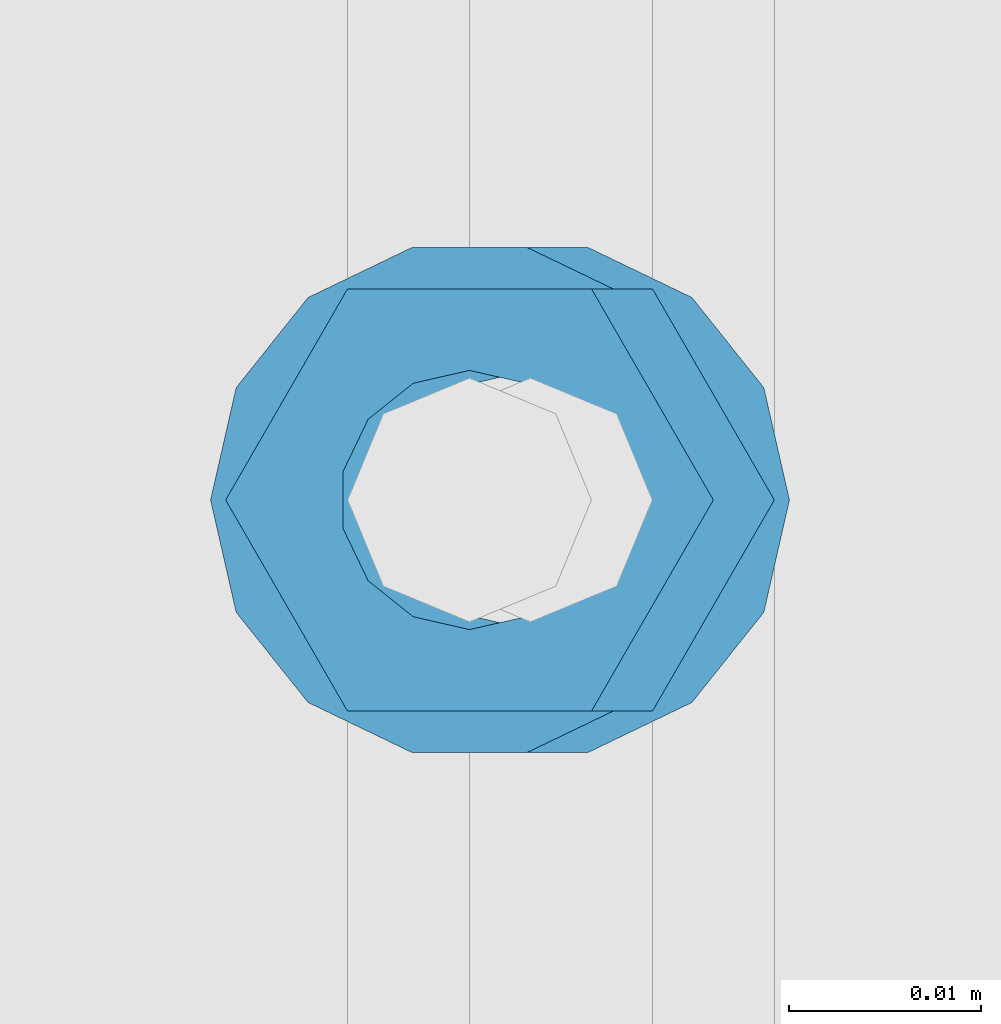
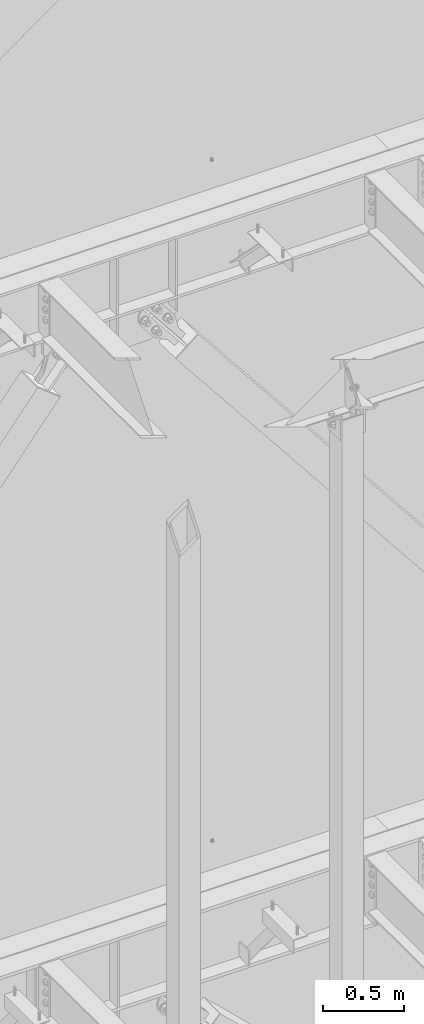
# One storey, part 685 of 1179: 4 columns, 2 elements without a shape of their own.
"""IFC2X3 building model written with IfcOpenShell, lengths in millimetres."""

from ifc_helpers import new_model, si_unit, frame, origin_with_axes, place, context, subcontext, project, spatial, faceted_brep, material, type_object, element, aggregate, save


model = new_model("IFC2X3")

# Units and contexts
model_context = context("Model", 3, precision=1e-05, world=origin_with_axes())
body_context = subcontext(model_context, "Body", "Model", "MODEL_VIEW")
ifc_project = project(units=[si_unit("LENGTHUNIT", "METRE", prefix="MILLI"), si_unit("AREAUNIT", "SQUARE_METRE"), si_unit("VOLUMEUNIT", "CUBIC_METRE"), si_unit("MASSUNIT", "GRAM", prefix="KILO"), si_unit("TIMEUNIT", "SECOND"), si_unit("PLANEANGLEUNIT", "RADIAN"), si_unit("SOLIDANGLEUNIT", "STERADIAN"), si_unit("THERMODYNAMICTEMPERATUREUNIT", "DEGREE_CELSIUS"), si_unit("LUMINOUSINTENSITYUNIT", "LUMEN")], contexts=[model_context])

# Site, building, storey
site_placement = place(None, origin_with_axes())
site = spatial("IfcSite", under=ifc_project, at=site_placement, CompositionType="ELEMENT")
building_placement = place(site_placement, origin_with_axes())
building = spatial("IfcBuilding", under=site, at=building_placement, Name="Undefined", CompositionType="ELEMENT")
storey_placement = place(building_placement, origin_with_axes())
storey = spatial("IfcBuildingStorey", under=building, at=storey_placement, Name="Undefined", CompositionType="ELEMENT", Elevation=0.0)

# Assembly, column
assembly_1_placement = place(storey_placement, origin_with_axes())
assembly_1 = element("IfcElementAssembly", 1, at=assembly_1_placement, inside=storey, Name="BEAM", AssemblyPlace="NOTDEFINED", PredefinedType="RIGID_FRAME")
ifc_material = material(Name="STEEL/A307")
column_type_1 = type_object("IfcColumnType", Name="1/2_WASHER", PredefinedType="NOTDEFINED")
column_1_placement = place(assembly_1_placement, frame((13284.2, 41529.0, 13252.45), z_axis=(0.0, 1.0, 0.0), x_axis=(0.0, 0.0, 1.0)))
column_1 = element("IfcColumn", 2, at=column_1_placement, type_object=column_type_1, material=ifc_material, Name="WASHER", ObjectType="1/2_WASHER", context=body_context, shape_type="Brep", body=[
    faceted_brep([(0.0, -13.4899997711182, 0.0), (0.0, -12.1540698217868, -5.85309154138758), (4.76249999999891, -12.1540698217868, -5.85309154138758), (4.76249999999891, -13.4899997711182, 0.0), (0.0, -8.41087728436833, -10.5469065195466), (4.76249999999891, -8.41087728436833, -10.5469065195466), (0.0, -3.00180734814057, -13.1517773121896), (4.76249999999891, -3.00180734814057, -13.1517773121896), (0.0, 3.00180734814057, -13.1517773121896), (4.76249999999891, 3.00180734814057, -13.1517773121896), (0.0, 8.41087728436833, -10.5469065195466), (4.76249999999891, 8.41087728436833, -10.5469065195466), (0.0, 12.1540698217868, -5.85309154138758), (4.76249999999891, 12.1540698217868, -5.85309154138758), (0.0, 13.4899997711182, 0.0), (4.76249999999891, 13.4899997711182, 0.0), (0.0, 12.1540698217868, 5.85309154138758), (4.76249999999891, 12.1540698217868, 5.85309154138758), (0.0, 8.41087728436833, 10.5469065195466), (4.76249999999891, 8.41087728436833, 10.5469065195466), (0.0, 3.00180734814057, 13.1517773121896), (4.76249999999891, 3.00180734814057, 13.1517773121896), (0.0, -3.00180734814057, 13.1517773121896), (4.76249999999891, -3.00180734814057, 13.1517773121896), (0.0, -8.41087728436833, 10.5469065195466), (4.76249999999891, -8.41087728436833, 10.5469065195466), (0.0, -12.1540698217868, 5.85309154138758), (4.76249999999891, -12.1540698217868, 5.85309154138758), (0.0, 0.0, 6.75), (0.0, 2.9287152390425, 6.08153985834178), (4.76249999999891, 2.9287152390425, 6.08153985834178), (4.76249999999891, 0.0, 6.75), (0.0, 5.27736250665839, 4.2085561625463), (4.76249999999891, 5.27736250665839, 4.2085561625463), (0.0, 6.58076340722619, 1.50201630420543), (4.76249999999891, 6.58076340722619, 1.50201630420543), (0.0, 6.58076340722619, -1.50201630420543), (4.76249999999891, 6.58076340722619, -1.50201630420543), (0.0, 5.27736250665839, -4.2085561625463), (4.76249999999891, 5.27736250665839, -4.2085561625463), (0.0, 2.9287152390425, -6.08153985834088), (4.76249999999891, 2.9287152390425, -6.08153985834088), (0.0, 0.0, -6.75), (4.76249999999891, 0.0, -6.75), (0.0, -2.9287152390425, -6.08153985834178), (4.76249999999891, -2.9287152390425, -6.08153985834178), (0.0, -5.27736250665839, -4.2085561625463), (4.76249999999891, -5.27736250665839, -4.2085561625463), (0.0, -6.58076340722619, -1.50201630420543), (4.76249999999891, -6.58076340722619, -1.50201630420543), (0.0, -6.58076340722619, 1.50201630420543), (4.76249999999891, -6.58076340722619, 1.50201630420543), (0.0, -5.27736250665839, 4.2085561625463), (4.76249999999891, -5.27736250665839, 4.2085561625463), (0.0, -2.9287152390425, 6.08153985834088), (4.76249999999891, -2.9287152390425, 6.08153985834088)], [[[0, 1, 2, 3]], [[1, 4, 5, 2]], [[4, 6, 7, 5]], [[6, 8, 9, 7]], [[8, 10, 11, 9]], [[10, 12, 13, 11]], [[12, 14, 15, 13]], [[14, 16, 17, 15]], [[16, 18, 19, 17]], [[18, 20, 21, 19]], [[20, 22, 23, 21]], [[22, 24, 25, 23]], [[24, 26, 27, 25]], [[26, 0, 3, 27]], [[28, 29, 30, 31]], [[29, 32, 33, 30]], [[32, 34, 35, 33]], [[34, 36, 37, 35]], [[36, 38, 39, 37]], [[38, 40, 41, 39]], [[40, 42, 43, 41]], [[42, 44, 45, 43]], [[44, 46, 47, 45]], [[46, 48, 49, 47]], [[48, 50, 51, 49]], [[50, 52, 53, 51]], [[52, 54, 55, 53]], [[54, 28, 31, 55]], [[5, 7, 9, 11, 13, 15, 17, 19, 21, 23, 25, 27, 3, 2], [33, 35, 37, 39, 41, 43, 45, 47, 49, 51, 53, 55, 31, 30]], [[26, 24, 22, 20, 18, 16, 14, 12, 10, 8, 6, 4, 1, 0], [54, 52, 50, 48, 46, 44, 42, 40, 38, 36, 34, 32, 29, 28]]]),
])

assembly_2_placement = place(storey_placement, origin_with_axes())
assembly_2 = element("IfcElementAssembly", 3, at=assembly_2_placement, inside=storey, Name="BEAM", AssemblyPlace="NOTDEFINED", PredefinedType="RIGID_FRAME")
column_2_placement = place(assembly_2_placement, frame((13287.375, 41529.0, 8147.05), z_axis=(0.0, 1.0, 0.0), x_axis=(0.0, 0.0, 1.0)))
column_2 = element("IfcColumn", 4, at=column_2_placement, type_object=column_type_1, material=ifc_material, Name="WASHER", ObjectType="1/2_WASHER", context=body_context, shape_type="Brep", body=[
    faceted_brep([(0.0, -13.4899997711182, 0.0), (0.0, -12.1540698217868, -5.85309154138758), (4.76249999999891, -12.1540698217868, -5.85309154138758), (4.76249999999891, -13.4899997711182, 0.0), (0.0, -8.41087728436833, -10.5469065195466), (4.76249999999891, -8.41087728436833, -10.5469065195466), (0.0, -3.00180734814057, -13.1517773121896), (4.76249999999891, -3.00180734814057, -13.1517773121896), (0.0, 3.00180734814057, -13.1517773121896), (4.76249999999891, 3.00180734814057, -13.1517773121896), (0.0, 8.41087728436833, -10.5469065195466), (4.76249999999891, 8.41087728436833, -10.5469065195466), (0.0, 12.1540698217868, -5.85309154138758), (4.76249999999891, 12.1540698217868, -5.85309154138758), (0.0, 13.4899997711182, 0.0), (4.76249999999891, 13.4899997711182, 0.0), (0.0, 12.1540698217868, 5.85309154138758), (4.76249999999891, 12.1540698217868, 5.85309154138758), (0.0, 8.41087728436833, 10.5469065195466), (4.76249999999891, 8.41087728436833, 10.5469065195466), (0.0, 3.00180734814057, 13.1517773121896), (4.76249999999891, 3.00180734814057, 13.1517773121896), (0.0, -3.00180734814057, 13.1517773121896), (4.76249999999891, -3.00180734814057, 13.1517773121896), (0.0, -8.41087728436833, 10.5469065195466), (4.76249999999891, -8.41087728436833, 10.5469065195466), (0.0, -12.1540698217868, 5.85309154138758), (4.76249999999891, -12.1540698217868, 5.85309154138758), (0.0, 0.0, 6.75), (0.0, 2.9287152390425, 6.08153985834178), (4.76249999999891, 2.9287152390425, 6.08153985834178), (4.76249999999891, 0.0, 6.75), (0.0, 5.27736250665839, 4.2085561625463), (4.76249999999891, 5.27736250665839, 4.2085561625463), (0.0, 6.58076340722619, 1.50201630420543), (4.76249999999891, 6.58076340722619, 1.50201630420543), (0.0, 6.58076340722619, -1.50201630420543), (4.76249999999891, 6.58076340722619, -1.50201630420543), (0.0, 5.27736250665839, -4.2085561625463), (4.76249999999891, 5.27736250665839, -4.2085561625463), (0.0, 2.9287152390425, -6.08153985834088), (4.76249999999891, 2.9287152390425, -6.08153985834088), (0.0, 0.0, -6.75), (4.76249999999891, 0.0, -6.75), (0.0, -2.9287152390425, -6.08153985834178), (4.76249999999891, -2.9287152390425, -6.08153985834178), (0.0, -5.27736250665839, -4.2085561625463), (4.76249999999891, -5.27736250665839, -4.2085561625463), (0.0, -6.58076340722619, -1.50201630420543), (4.76249999999891, -6.58076340722619, -1.50201630420543), (0.0, -6.58076340722619, 1.50201630420543), (4.76249999999891, -6.58076340722619, 1.50201630420543), (0.0, -5.27736250665839, 4.2085561625463), (4.76249999999891, -5.27736250665839, 4.2085561625463), (0.0, -2.9287152390425, 6.08153985834088), (4.76249999999891, -2.9287152390425, 6.08153985834088)], [[[0, 1, 2, 3]], [[1, 4, 5, 2]], [[4, 6, 7, 5]], [[6, 8, 9, 7]], [[8, 10, 11, 9]], [[10, 12, 13, 11]], [[12, 14, 15, 13]], [[14, 16, 17, 15]], [[16, 18, 19, 17]], [[18, 20, 21, 19]], [[20, 22, 23, 21]], [[22, 24, 25, 23]], [[24, 26, 27, 25]], [[26, 0, 3, 27]], [[28, 29, 30, 31]], [[29, 32, 33, 30]], [[32, 34, 35, 33]], [[34, 36, 37, 35]], [[36, 38, 39, 37]], [[38, 40, 41, 39]], [[40, 42, 43, 41]], [[42, 44, 45, 43]], [[44, 46, 47, 45]], [[46, 48, 49, 47]], [[48, 50, 51, 49]], [[50, 52, 53, 51]], [[52, 54, 55, 53]], [[54, 28, 31, 55]], [[5, 7, 9, 11, 13, 15, 17, 19, 21, 23, 25, 27, 3, 2], [33, 35, 37, 39, 41, 43, 45, 47, 49, 51, 53, 55, 31, 30]], [[26, 24, 22, 20, 18, 16, 14, 12, 10, 8, 6, 4, 1, 0], [54, 52, 50, 48, 46, 44, 42, 40, 38, 36, 34, 32, 29, 28]]]),
])

# Column
column_type_2 = type_object("IfcColumnType", Name="1/2_HEAVY_HEX_NUT", PredefinedType="NOTDEFINED")
column_3_placement = place(assembly_1_placement, frame((13284.2, 41529.0, 13257.2125), z_axis=(0.0, 1.0, 0.0), x_axis=(0.0, 0.0, 1.0)))
column_3 = element("IfcColumn", 5, at=column_3_placement, type_object=column_type_2, material=ifc_material, Name="NUT", ObjectType="1/2_HEAVY_HEX_NUT", context=body_context, shape_type="Brep", body=[
    faceted_brep([(0.0, -12.7, 0.0), (0.0, -6.34999990463257, -11.0), (12.7000000000007, -6.34999990463257, -11.0), (12.7000000000007, -12.6999998092651, 0.0), (0.0, 6.34999990463257, -11.0), (12.7000000000007, 6.34999990463257, -11.0), (0.0, 12.7, 0.0), (12.7000000000007, 12.6999998092651, 0.0), (0.0, 6.34999990463257, 11.0), (12.7000000000007, 6.34999990463257, 11.0), (0.0, -6.34999990463257, 11.0), (12.7000000000007, -6.34999990463257, 11.0), (0.0, 0.0, 6.75), (0.0, 2.9287152390425, 6.08153985834178), (12.7000000000007, 2.9287152390425, 6.08153985834178), (12.7000000000007, 0.0, 6.75), (0.0, 5.27736250665839, 4.2085561625463), (12.7000000000007, 5.27736250665839, 4.2085561625463), (0.0, 6.58076340722619, 1.50201630420543), (12.7000000000007, 6.58076340722619, 1.50201630420543), (0.0, 6.58076340722619, -1.50201630420543), (12.7000000000007, 6.58076340722619, -1.50201630420543), (0.0, 5.27736250665839, -4.2085561625463), (12.7000000000007, 5.27736250665839, -4.2085561625463), (0.0, 2.9287152390425, -6.08153985834088), (12.7000000000007, 2.9287152390425, -6.08153985834088), (0.0, 0.0, -6.75), (12.7000000000007, 0.0, -6.75), (0.0, -2.9287152390425, -6.08153985834178), (12.7000000000007, -2.9287152390425, -6.08153985834178), (0.0, -5.27736250665839, -4.2085561625463), (12.7000000000007, -5.27736250665839, -4.2085561625463), (0.0, -6.58076340722619, -1.50201630420543), (12.7000000000007, -6.58076340722619, -1.50201630420543), (0.0, -6.58076340722619, 1.50201630420543), (12.7000000000007, -6.58076340722619, 1.50201630420543), (0.0, -5.27736250665839, 4.2085561625463), (12.7000000000007, -5.27736250665839, 4.2085561625463), (0.0, -2.9287152390425, 6.08153985834088), (12.7000000000007, -2.9287152390425, 6.08153985834088)], [[[0, 1, 2, 3]], [[1, 4, 5, 2]], [[4, 6, 7, 5]], [[6, 8, 9, 7]], [[8, 10, 11, 9]], [[10, 0, 3, 11]], [[12, 13, 14, 15]], [[13, 16, 17, 14]], [[16, 18, 19, 17]], [[18, 20, 21, 19]], [[20, 22, 23, 21]], [[22, 24, 25, 23]], [[24, 26, 27, 25]], [[26, 28, 29, 27]], [[28, 30, 31, 29]], [[30, 32, 33, 31]], [[32, 34, 35, 33]], [[34, 36, 37, 35]], [[36, 38, 39, 37]], [[38, 12, 15, 39]], [[5, 7, 9, 11, 3, 2], [17, 19, 21, 23, 25, 27, 29, 31, 33, 35, 37, 39, 15, 14]], [[10, 8, 6, 4, 1, 0], [38, 36, 34, 32, 30, 28, 26, 24, 22, 20, 18, 16, 13, 12]]]),
])

aggregate(assembly_1, [column_1, column_3])

column_4_placement = place(assembly_2_placement, frame((13287.375, 41529.0, 8151.8125), z_axis=(0.0, 1.0, 0.0), x_axis=(0.0, 0.0, 1.0)))
column_4 = element("IfcColumn", 6, at=column_4_placement, type_object=column_type_2, material=ifc_material, Name="NUT", ObjectType="1/2_HEAVY_HEX_NUT", context=body_context, shape_type="Brep", body=[
    faceted_brep([(0.0, -12.7, 0.0), (0.0, -6.34999990463257, -11.0), (12.7000000000007, -6.34999990463257, -11.0), (12.7000000000007, -12.6999998092651, 0.0), (0.0, 6.34999990463257, -11.0), (12.7000000000007, 6.34999990463257, -11.0), (0.0, 12.7, 0.0), (12.7000000000007, 12.6999998092651, 0.0), (0.0, 6.34999990463257, 11.0), (12.7000000000007, 6.34999990463257, 11.0), (0.0, -6.34999990463257, 11.0), (12.7000000000007, -6.34999990463257, 11.0), (0.0, 0.0, 6.75), (0.0, 2.9287152390425, 6.08153985834178), (12.7000000000007, 2.9287152390425, 6.08153985834178), (12.7000000000007, 0.0, 6.75), (0.0, 5.27736250665839, 4.2085561625463), (12.7000000000007, 5.27736250665839, 4.2085561625463), (0.0, 6.58076340722619, 1.50201630420543), (12.7000000000007, 6.58076340722619, 1.50201630420543), (0.0, 6.58076340722619, -1.50201630420543), (12.7000000000007, 6.58076340722619, -1.50201630420543), (0.0, 5.27736250665839, -4.2085561625463), (12.7000000000007, 5.27736250665839, -4.2085561625463), (0.0, 2.9287152390425, -6.08153985834088), (12.7000000000007, 2.9287152390425, -6.08153985834088), (0.0, 0.0, -6.75), (12.7000000000007, 0.0, -6.75), (0.0, -2.9287152390425, -6.08153985834178), (12.7000000000007, -2.9287152390425, -6.08153985834178), (0.0, -5.27736250665839, -4.2085561625463), (12.7000000000007, -5.27736250665839, -4.2085561625463), (0.0, -6.58076340722619, -1.50201630420543), (12.7000000000007, -6.58076340722619, -1.50201630420543), (0.0, -6.58076340722619, 1.50201630420543), (12.7000000000007, -6.58076340722619, 1.50201630420543), (0.0, -5.27736250665839, 4.2085561625463), (12.7000000000007, -5.27736250665839, 4.2085561625463), (0.0, -2.9287152390425, 6.08153985834088), (12.7000000000007, -2.9287152390425, 6.08153985834088)], [[[0, 1, 2, 3]], [[1, 4, 5, 2]], [[4, 6, 7, 5]], [[6, 8, 9, 7]], [[8, 10, 11, 9]], [[10, 0, 3, 11]], [[12, 13, 14, 15]], [[13, 16, 17, 14]], [[16, 18, 19, 17]], [[18, 20, 21, 19]], [[20, 22, 23, 21]], [[22, 24, 25, 23]], [[24, 26, 27, 25]], [[26, 28, 29, 27]], [[28, 30, 31, 29]], [[30, 32, 33, 31]], [[32, 34, 35, 33]], [[34, 36, 37, 35]], [[36, 38, 39, 37]], [[38, 12, 15, 39]], [[5, 7, 9, 11, 3, 2], [17, 19, 21, 23, 25, 27, 29, 31, 33, 35, 37, 39, 15, 14]], [[10, 8, 6, 4, 1, 0], [38, 36, 34, 32, 30, 28, 26, 24, 22, 20, 18, 16, 13, 12]]]),
])

aggregate(assembly_2, [column_2, column_4])

save(model, "model.ifc")
